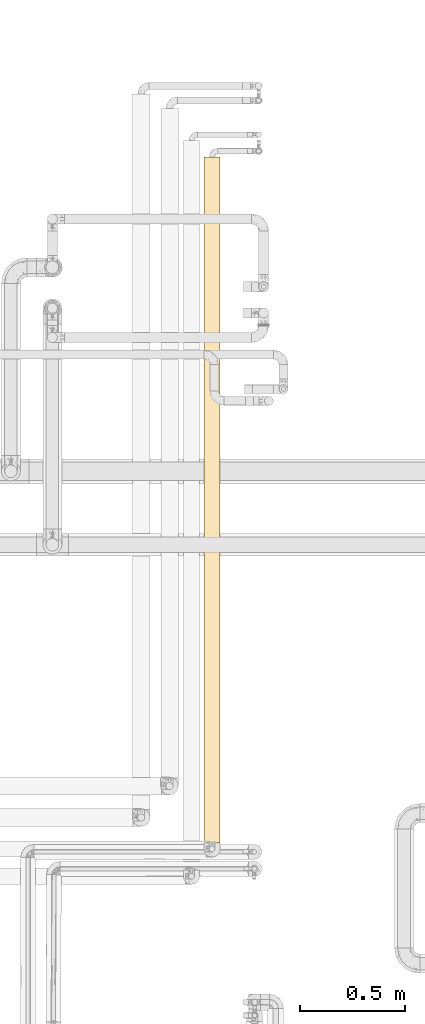
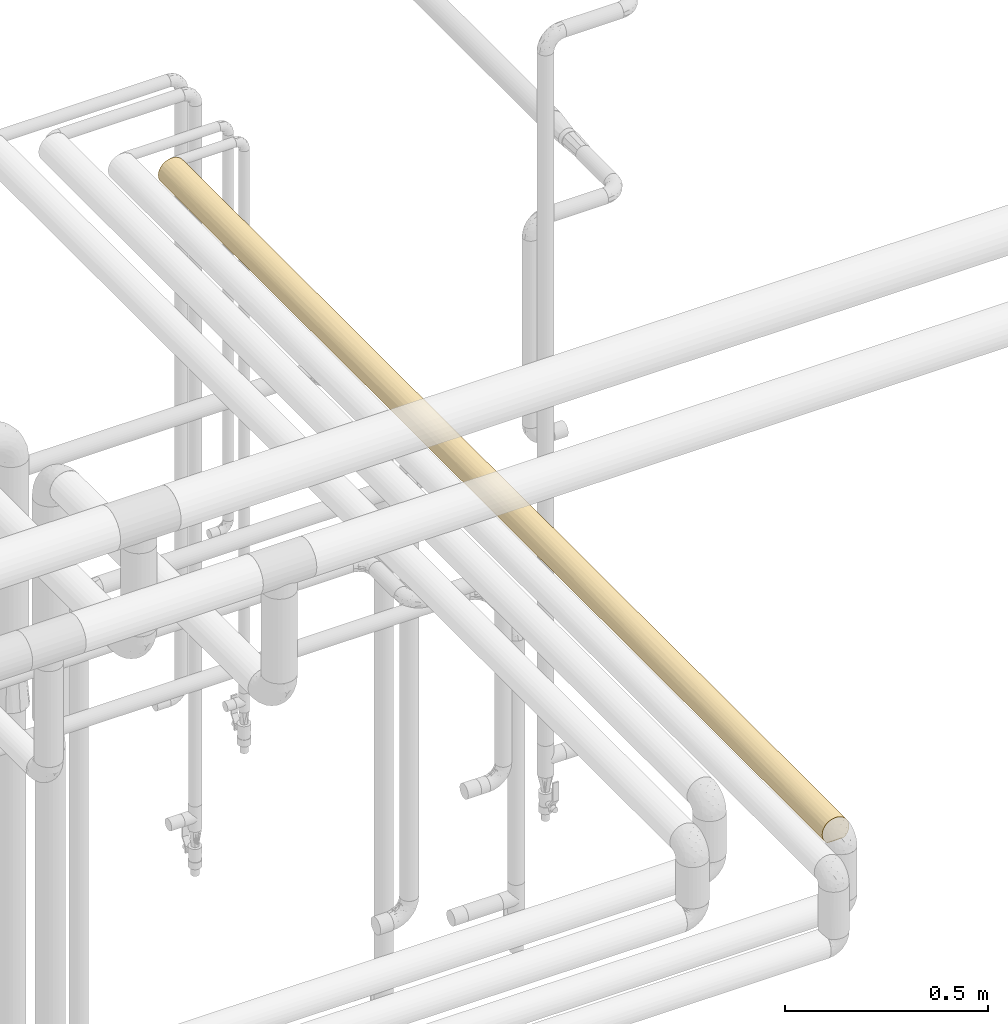
# One storey, part 34 of 827: 1 covering.
"""IFC2X3 building model written with IfcOpenShell, lengths in millimetres."""

from ifc_helpers import new_model, entity, si_unit, converted_unit, derived_unit, direction, frame, origin, place, context, subcontext, project, spatial, faceted_brep, element, save


model = new_model("IFC2X3")

# Units and contexts
model_context = context("Model", 3, precision=0.01, world=origin(), true_north=direction((6.12303176911189e-17, 1.0)))
body_context = subcontext(model_context, "Body", "Model", "MODEL_VIEW")
ifc_project = project(units=[si_unit("LENGTHUNIT", "METRE", prefix="MILLI"), si_unit("AREAUNIT", "SQUARE_METRE"), si_unit("VOLUMEUNIT", "CUBIC_METRE"), converted_unit("PLANEANGLEUNIT", "DEGREE", entity("IfcRatioMeasure", 0.0174532925199433), si_unit("PLANEANGLEUNIT", "RADIAN"), dimensions=[0, 0, 0, 0, 0, 0, 0]), si_unit("MASSUNIT", "GRAM", prefix="KILO"), derived_unit("MASSDENSITYUNIT", [(si_unit("MASSUNIT", "GRAM", prefix="KILO"), 1), (si_unit("LENGTHUNIT", "METRE"), -3)]), derived_unit("MOMENTOFINERTIAUNIT", [(si_unit("LENGTHUNIT", "METRE"), 4)]), si_unit("TIMEUNIT", "SECOND"), si_unit("FREQUENCYUNIT", "HERTZ"), si_unit("THERMODYNAMICTEMPERATUREUNIT", "DEGREE_CELSIUS"), derived_unit("THERMALTRANSMITTANCEUNIT", [(si_unit("MASSUNIT", "GRAM", prefix="KILO"), 1), (si_unit("THERMODYNAMICTEMPERATUREUNIT", "KELVIN"), -1), (si_unit("TIMEUNIT", "SECOND"), -3)]), derived_unit("VOLUMETRICFLOWRATEUNIT", [(si_unit("LENGTHUNIT", "METRE"), 3), (si_unit("TIMEUNIT", "SECOND"), -1)]), derived_unit("MASSFLOWRATEUNIT", [(si_unit("MASSUNIT", "GRAM", prefix="KILO"), 1), (si_unit("TIMEUNIT", "SECOND"), -1)]), derived_unit("ROTATIONALFREQUENCYUNIT", [(si_unit("TIMEUNIT", "SECOND"), -1)]), si_unit("ELECTRICCURRENTUNIT", "AMPERE"), si_unit("ELECTRICVOLTAGEUNIT", "VOLT"), si_unit("POWERUNIT", "WATT"), si_unit("FORCEUNIT", "NEWTON", prefix="KILO"), si_unit("ILLUMINANCEUNIT", "LUX"), si_unit("LUMINOUSFLUXUNIT", "LUMEN"), si_unit("LUMINOUSINTENSITYUNIT", "CANDELA"), derived_unit("USERDEFINED", [(si_unit("MASSUNIT", "GRAM", prefix="KILO"), -1), (si_unit("LENGTHUNIT", "METRE"), -2), (si_unit("TIMEUNIT", "SECOND"), 3), (si_unit("LUMINOUSFLUXUNIT", "LUMEN"), 1)]), derived_unit("LINEARVELOCITYUNIT", [(si_unit("LENGTHUNIT", "METRE"), 1), (si_unit("TIMEUNIT", "SECOND"), -1)]), si_unit("PRESSUREUNIT", "PASCAL"), derived_unit("USERDEFINED", [(si_unit("LENGTHUNIT", "METRE"), -2), (si_unit("MASSUNIT", "GRAM", prefix="KILO"), 1), (si_unit("TIMEUNIT", "SECOND"), -2)]), derived_unit("LINEARFORCEUNIT", [(si_unit("MASSUNIT", "GRAM", prefix="KILO"), 1), (si_unit("LENGTHUNIT", "METRE"), 1), (si_unit("TIMEUNIT", "SECOND"), -2), (si_unit("LENGTHUNIT", "METRE"), -1)]), derived_unit("PLANARFORCEUNIT", [(si_unit("MASSUNIT", "GRAM", prefix="KILO"), 1), (si_unit("LENGTHUNIT", "METRE"), 1), (si_unit("TIMEUNIT", "SECOND"), -2), (si_unit("LENGTHUNIT", "METRE"), -2)])], contexts=[model_context])

# Site, building, storey
site_placement = place(None, origin())
site = spatial("IfcSite", under=ifc_project, at=site_placement, CompositionType="ELEMENT")
building_placement = place(site_placement, origin())
building = spatial("IfcBuilding", under=site, at=building_placement, CompositionType="ELEMENT")
storey_placement = place(building_placement, frame((0.0, 0.0, 28200.0)))
storey = spatial("IfcBuildingStorey", under=building, at=storey_placement, Name="08", CompositionType="ELEMENT", Elevation=28200.0)

# Covering
covering_placement = place(storey_placement, frame((18643.06, 12977.5, 2560.0)))
element("IfcCovering", 1, at=covering_placement, inside=storey, Name=":ADSK_", ObjectType=":ADSK_", PredefinedType="INSULATION", context=body_context, shape_type="Brep", body=[
    faceted_brep([(5.09, 1.6, 23.98), (9.31, 1.6, 16.91), (14.94, 1.6, 10.9), (65.05, 1.6, 10.9), (70.68, 1.6, 16.91), (74.9, 1.6, 23.98), (77.51, 1.6, 31.79), (78.4, 1.6, 40.0), (77.09, 1.6, 49.93), (73.25, 1.6, 59.2), (67.15, 1.6, 67.15), (59.2, 1.6, 73.25), (49.93, 1.6, 77.09), (40.0, 1.6, 78.4), (30.06, 1.6, 77.09), (20.8, 1.6, 73.25), (12.84, 1.6, 67.15), (6.74, 1.6, 59.2), (2.9, 1.6, 49.93), (1.6, 1.6, 40.0), (2.48, 1.6, 31.79), (20.8, 3269.97, 6.74), (12.84, 3269.97, 12.84), (6.74, 3269.97, 20.8), (2.9, 3269.97, 30.06), (1.6, 3269.97, 40.0), (2.9, 3269.97, 49.93), (6.74, 3269.97, 59.2), (12.84, 3269.97, 67.15), (20.8, 3269.97, 73.25), (30.06, 3269.97, 77.09), (40.0, 3269.97, 78.4), (49.93, 3269.97, 77.09), (59.2, 3269.97, 73.25), (67.15, 3269.97, 67.15), (73.25, 3269.97, 59.2), (77.09, 3269.97, 49.93), (78.4, 3269.97, 40.0), (77.09, 3269.97, 30.06), (73.25, 3269.97, 20.8), (67.15, 3269.97, 12.84), (59.2, 3269.97, 6.74), (49.93, 3269.97, 2.9), (40.0, 3269.97, 1.6), (30.06, 3269.97, 2.9), (9.53, 3010.78, 16.62), (3.58, 287.23, 27.82), (7.01, 218.66, 20.33), (2.29, 2945.41, 32.71), (2.42, 2648.32, 32.07), (1.6, 2837.22, 40.0), (40.0, 3053.6, 1.6), (11.96, 287.24, 13.75), (27.74, 2411.32, 3.6), (17.45, 2441.81, 8.91), (25.3, 2740.25, 4.52), (15.56, 482.9, 10.37), (11.05, 642.7, 14.76), (25.3, 3024.92, 4.52), (6.82, 785.7, 20.65), (6.41, 1085.46, 21.37), (12.04, 950.32, 13.67), (20.48, 5.57, 6.92), (23.31, 384.99, 5.41), (26.63, 8.5, 4.0), (29.53, 688.07, 3.05), (29.96, 1009.3, 2.93), (40.0, 876.39, 1.6), (7.01, 485.18, 20.33), (3.13, 914.93, 29.25), (2.85, 616.82, 30.25), (1.6, 217.97, 40.0), (3.89, 3075.32, 26.92), (4.52, 2864.65, 25.3), (30.06, 1571.68, 2.9), (31.96, 1342.7, 2.45), (24.44, 1282.91, 4.89), (40.0, 660.01, 1.6), (40.0, 443.64, 1.6), (29.69, 2162.87, 3.0), (40.0, 2404.48, 1.6), (40.0, 2073.18, 1.6), (5.69, 2271.69, 22.74), (9.53, 2546.31, 16.62), (12.23, 2165.35, 13.47), (32.71, 2945.41, 2.29), (31.75, 335.45, 2.49), (33.21, 10.29, 2.2), (17.64, 278.27, 8.77), (16.62, 2945.7, 9.53), (3.15, 2416.6, 29.19), (5.14, 2608.73, 23.87), (40.0, 227.27, 1.6), (40.0, 10.9, 1.6), (33.12, 2708.32, 2.22), (1.6, 3053.6, 40.0), (1.6, 434.34, 40.0), (17.89, 2702.85, 8.6), (11.76, 2778.54, 13.97), (7.41, 2764.76, 19.68), (22.88, 606.06, 5.62), (23.89, 824.3, 5.13), (20.15, 1008.07, 7.12), (2.89, 1214.71, 30.1), (2.17, 1410.78, 33.38), (5.1, 1514.03, 23.97), (21.55, 2136.0, 6.32), (13.21, 1309.36, 12.48), (7.75, 1322.72, 19.14), (9.43, 1672.96, 16.75), (1.6, 867.09, 40.0), (1.6, 650.71, 40.0), (23.71, 1722.29, 5.22), (29.73, 1907.53, 2.99), (2.76, 1900.55, 30.62), (1.6, 1732.58, 40.0), (1.6, 1755.36, 40.0), (1.6, 1971.73, 40.0), (1.6, 2068.53, 40.0), (40.0, 2837.22, 1.6), (40.0, 2620.85, 1.6), (40.0, 1741.88, 1.6), (16.5, 1685.42, 9.62), (18.92, 1911.29, 7.9), (18.53, 1316.67, 8.16), (6.95, 1935.25, 20.43), (12.47, 1900.89, 13.22), (2.61, 2177.15, 31.22), (40.0, 1092.76, 1.6), (40.0, 1525.51, 1.6), (20.92, 1497.18, 6.67), (2.48, 1624.39, 31.78), (4.55, 1739.98, 25.23), (1.6, 1516.21, 40.0), (1.6, 1299.83, 40.0), (1.6, 2404.48, 40.0), (1.6, 2620.85, 40.0), (17.22, 717.19, 9.08), (1.6, 1083.46, 40.0), (1.6, 1538.99, 40.0), (1.6, 2188.11, 40.0), (40.0, 1309.13, 1.6), (1.6, 1203.04, 40.0), (75.47, 3024.92, 25.3), (56.56, 857.24, 5.35), (50.46, 688.07, 3.05), (50.03, 1009.3, 2.93), (63.37, 3010.78, 9.53), (72.98, 218.66, 20.33), (72.98, 485.18, 20.33), (76.41, 287.23, 27.82), (53.36, 8.5, 4.0), (46.78, 10.29, 2.2), (48.24, 335.45, 2.49), (55.9, 2520.7, 5.04), (60.1, 2733.21, 7.28), (63.37, 2546.31, 9.53), (78.4, 3053.6, 40.0), (57.31, 2271.77, 5.72), (66.54, 2165.74, 12.25), (70.04, 919.72, 16.08), (73.58, 1085.46, 21.37), (73.95, 783.02, 22.06), (56.68, 384.99, 5.41), (59.51, 5.57, 6.92), (65.02, 1839.13, 10.87), (55.52, 1623.09, 4.87), (59.59, 1936.52, 6.97), (68.03, 287.24, 13.75), (53.07, 3075.32, 3.89), (47.28, 2945.41, 2.29), (48.23, 1681.27, 2.49), (48.25, 1452.35, 2.49), (70.46, 2945.7, 16.62), (77.14, 616.82, 30.25), (78.4, 434.34, 40.0), (77.09, 953.6, 30.08), (71.08, 2441.81, 17.45), (75.47, 2740.25, 25.3), (76.39, 2411.32, 27.74), (65.4, 500.22, 11.2), (62.6, 316.33, 8.96), (77.7, 2945.41, 32.71), (54.69, 2864.65, 4.52), (49.4, 1907.53, 2.77), (69.32, 674.48, 15.2), (78.4, 217.97, 40.0), (77.77, 2708.32, 33.12), (47.92, 2648.32, 2.42), (62.77, 717.19, 9.08), (71.39, 2702.85, 17.89), (66.03, 2778.54, 11.76), (64.73, 1082.09, 10.62), (76.56, 1186.26, 28.26), (78.4, 1251.44, 40.0), (57.11, 606.06, 5.62), (55.55, 1282.91, 4.89), (64.89, 1453.94, 10.76), (78.4, 2404.48, 40.0), (78.4, 2020.13, 40.0), (77.3, 2137.55, 30.89), (73.35, 1902.54, 20.97), (76.71, 1827.96, 28.73), (78.4, 867.09, 40.0), (78.4, 650.71, 40.0), (74.21, 1674.15, 22.56), (78.4, 2837.23, 40.0), (78.4, 2620.85, 40.0), (73.68, 2136.0, 21.55), (76.56, 1425.24, 28.26), (76.74, 1626.22, 28.86), (78.4, 1635.78, 40.0), (69.16, 1973.33, 15.02), (71.97, 1463.8, 18.73), (69.64, 1124.78, 15.59), (47.0, 2443.34, 2.24), (48.04, 2238.83, 2.45), (47.35, 1224.47, 2.31), (69.81, 1753.65, 15.79), (56.7, 1071.61, 5.42), (63.37, 725.25, 70.46), (66.97, 1097.92, 67.33), (58.66, 997.02, 73.55), (70.46, 2945.7, 63.37), (70.46, 325.87, 63.37), (75.47, 3024.92, 54.69), (77.77, 2708.32, 46.88), (75.47, 2740.25, 54.69), (76.39, 2411.32, 52.25), (75.47, 246.65, 54.69), (75.47, 531.31, 54.69), (77.7, 326.15, 47.28), (77.7, 2945.41, 47.28), (53.07, 196.25, 76.1), (47.28, 326.15, 77.7), (54.69, 406.92, 75.47), (53.87, 721.15, 75.8), (71.37, 2511.14, 62.14), (73.68, 2136.0, 58.44), (63.37, 260.79, 70.46), (47.61, 1799.87, 77.63), (58.62, 1900.2, 73.58), (49.32, 2075.07, 77.25), (71.08, 829.75, 62.54), (76.39, 860.24, 52.25), (60.1, 2733.21, 72.71), (55.74, 2517.59, 75.02), (63.37, 2546.31, 70.46), (69.59, 1291.22, 64.47), (60.28, 1309.05, 72.6), (53.07, 3075.32, 76.1), (47.28, 2945.41, 77.7), (73.68, 1135.57, 58.44), (77.3, 1134.01, 49.1), (73.63, 1373.61, 58.52), (63.37, 3010.78, 70.46), (66.03, 2778.54, 68.23), (77.77, 563.24, 46.88), (47.1, 575.88, 77.73), (40.0, 434.34, 78.4), (40.0, 2837.22, 78.4), (40.0, 3053.6, 78.4), (40.0, 217.97, 78.4), (54.69, 2864.65, 75.47), (47.92, 2648.32, 77.57), (71.39, 568.72, 62.1), (66.03, 493.02, 68.23), (60.1, 538.36, 72.71), (70.94, 2728.5, 62.74), (77.3, 2137.55, 49.1), (76.71, 1443.61, 51.26), (66.93, 2236.36, 67.36), (76.68, 1825.68, 51.33), (56.6, 2260.66, 74.62), (40.0, 1538.99, 78.4), (50.86, 1200.22, 76.82), (52.17, 1555.42, 76.41), (40.0, 1251.44, 78.4), (40.0, 1203.04, 78.4), (68.5, 1875.9, 65.72), (74.35, 1633.67, 57.15), (61.47, 1611.08, 71.83), (73.41, 1869.19, 58.91), (40.0, 867.09, 78.4), (47.04, 793.01, 77.74), (45.92, 1021.5, 77.93), (48.83, 2365.17, 77.36), (52.33, 932.05, 76.36), (40.0, 650.71, 78.4), (69.92, 1514.01, 64.05), (40.0, 2620.85, 78.4), (40.0, 2404.48, 78.4), (40.0, 2188.1, 78.4), (40.0, 1971.73, 78.4), (40.0, 1755.36, 78.4), (40.0, 1635.78, 78.4), (40.0, 2020.13, 78.4), (9.53, 725.25, 63.37), (12.66, 1097.92, 66.97), (6.44, 997.02, 58.66), (16.62, 2945.7, 70.46), (16.62, 325.87, 70.46), (25.3, 3024.92, 75.47), (33.12, 2708.32, 77.77), (25.3, 2740.25, 75.47), (27.74, 2411.32, 76.39), (25.3, 246.65, 75.47), (25.3, 531.31, 75.47), (32.71, 326.15, 77.7), (32.71, 2945.41, 77.7), (3.89, 196.25, 53.07), (2.29, 326.15, 47.28), (4.52, 406.92, 54.69), (4.19, 721.15, 53.87), (17.85, 2511.14, 71.37), (21.55, 2136.0, 73.68), (9.53, 260.79, 63.37), (2.36, 1799.87, 47.61), (6.41, 1900.2, 58.62), (2.74, 2075.07, 49.32), (17.45, 829.75, 71.08), (27.74, 860.24, 76.39), (7.28, 2733.21, 60.1), (4.97, 2517.59, 55.74), (9.53, 2546.31, 63.37), (15.52, 1291.22, 69.59), (7.39, 1309.05, 60.28), (3.89, 3075.32, 53.07), (2.29, 2945.41, 47.28), (21.55, 1135.57, 73.68), (30.89, 1134.01, 77.3), (21.47, 1373.61, 73.63), (9.53, 3010.78, 63.37), (11.76, 2778.54, 66.03), (33.12, 563.24, 77.77), (2.26, 575.88, 47.1), (4.52, 2864.65, 54.69), (2.42, 2648.32, 47.92), (17.89, 568.72, 71.39), (11.76, 493.02, 66.03), (7.28, 538.36, 60.1), (17.25, 2728.5, 70.94), (30.89, 2137.55, 77.3), (28.73, 1443.61, 76.71), (12.63, 2236.36, 66.93), (28.66, 1825.68, 76.68), (5.37, 2260.66, 56.6), (3.17, 1200.22, 50.86), (3.58, 1555.42, 52.17), (14.27, 1875.9, 68.5), (22.84, 1633.67, 74.35), (8.16, 1611.08, 61.47), (21.08, 1869.19, 73.41), (2.25, 793.01, 47.04), (2.06, 1021.5, 45.92), (2.63, 2365.17, 48.83), (3.63, 932.05, 52.33), (15.94, 1514.01, 69.92)], [[[0, 1, 2, 3, 4, 5, 6, 7, 8, 9, 10, 11, 12, 13, 14, 15, 16, 17, 18, 19, 20]], [[21, 22, 23, 24, 25, 26, 27, 28, 29, 30, 31, 32, 33, 34, 35, 36, 37, 38, 39, 40, 41, 42, 43, 44]], [[22, 45, 23]], [[46, 47, 0]], [[48, 49, 50]], [[44, 43, 51]], [[52, 1, 47]], [[53, 54, 55]], [[56, 52, 57]], [[44, 58, 21]], [[59, 60, 61]], [[62, 63, 64]], [[65, 66, 67]], [[52, 68, 57]], [[69, 59, 70]], [[20, 19, 71]], [[48, 72, 73]], [[74, 75, 76]], [[77, 78, 65, 67]], [[2, 1, 52]], [[79, 80, 81]], [[82, 83, 84]], [[58, 85, 55]], [[47, 68, 52]], [[86, 65, 78]], [[87, 64, 86]], [[2, 52, 88]], [[21, 58, 89]], [[68, 46, 70]], [[90, 91, 82]], [[92, 93, 87]], [[46, 0, 20]], [[94, 53, 55]], [[21, 89, 22]], [[45, 22, 89]], [[24, 72, 48]], [[24, 48, 95]], [[86, 64, 63]], [[78, 92, 86]], [[52, 56, 88]], [[46, 71, 96]], [[70, 46, 96]], [[89, 97, 98]], [[55, 85, 94]], [[99, 45, 98]], [[54, 84, 83]], [[87, 86, 92]], [[86, 63, 65]], [[63, 100, 65]], [[66, 65, 101]], [[102, 76, 66]], [[103, 104, 105]], [[53, 79, 106]], [[107, 108, 109]], [[110, 70, 96, 111]], [[59, 69, 60]], [[98, 45, 89]], [[20, 71, 46]], [[72, 45, 73]], [[112, 113, 74]], [[114, 115, 116, 117, 118]], [[51, 85, 44]], [[89, 58, 55]], [[85, 51, 119]], [[85, 119, 94]], [[44, 85, 58]], [[94, 119, 120, 80]], [[53, 106, 54]], [[94, 80, 53]], [[113, 106, 79]], [[74, 113, 121]], [[113, 81, 121]], [[122, 123, 112]], [[124, 102, 107]], [[109, 125, 126]], [[84, 54, 106]], [[98, 97, 83]], [[126, 123, 122]], [[84, 125, 82]], [[127, 125, 114]], [[127, 90, 82]], [[75, 128, 66]], [[125, 127, 82]], [[74, 121, 129]], [[112, 130, 122]], [[114, 118, 127]], [[131, 132, 105]], [[105, 132, 109]], [[69, 103, 60]], [[95, 48, 50]], [[133, 104, 134]], [[95, 25, 24]], [[49, 48, 73]], [[83, 82, 91]], [[49, 135, 136, 50]], [[24, 23, 72]], [[45, 72, 23]], [[65, 100, 101]], [[66, 76, 75]], [[137, 61, 102]], [[102, 61, 107]], [[108, 107, 60]], [[130, 107, 122]], [[59, 57, 68]], [[107, 61, 60]], [[57, 61, 137]], [[70, 59, 68]], [[110, 69, 70]], [[69, 138, 103]], [[131, 133, 139, 115]], [[108, 103, 105]], [[133, 131, 104]], [[115, 114, 131]], [[132, 131, 114]], [[114, 125, 132]], [[84, 126, 125]], [[125, 109, 132]], [[107, 109, 122]], [[123, 84, 106]], [[122, 109, 126]], [[84, 123, 126]], [[113, 123, 106]], [[113, 112, 123]], [[130, 74, 76]], [[74, 130, 112]], [[124, 130, 76]], [[127, 118, 140, 135]], [[90, 135, 49]], [[135, 90, 127]], [[90, 49, 91]], [[49, 73, 91]], [[99, 91, 73]], [[89, 55, 97]], [[83, 91, 99]], [[55, 54, 97]], [[83, 97, 54]], [[61, 57, 59]], [[57, 137, 56]], [[100, 56, 137]], [[88, 56, 63]], [[63, 62, 88]], [[2, 88, 62]], [[105, 104, 131]], [[134, 104, 103]], [[102, 124, 76]], [[107, 130, 124]], [[0, 47, 1]], [[68, 47, 46]], [[45, 99, 73]], [[83, 99, 98]], [[56, 100, 63]], [[101, 137, 102]], [[137, 101, 100]], [[66, 101, 102]], [[80, 79, 53]], [[81, 113, 79]], [[129, 75, 74]], [[75, 129, 141, 128]], [[103, 108, 60]], [[128, 67, 66]], [[109, 108, 105]], [[138, 69, 110]], [[103, 138, 142, 134]], [[38, 143, 39]], [[144, 145, 146]], [[41, 40, 147]], [[148, 149, 150]], [[151, 152, 153]], [[154, 155, 156]], [[38, 37, 157]], [[158, 156, 159]], [[160, 161, 162]], [[151, 163, 164]], [[165, 166, 167]], [[168, 148, 4]], [[42, 169, 170]], [[171, 166, 172]], [[39, 143, 173]], [[150, 174, 175]], [[174, 162, 176]], [[177, 178, 179]], [[3, 168, 4]], [[180, 181, 163]], [[143, 182, 178]], [[170, 169, 183]], [[153, 145, 163]], [[148, 5, 4]], [[78, 153, 92]], [[184, 121, 81]], [[149, 180, 185]], [[92, 153, 152]], [[5, 150, 6]], [[150, 186, 6]], [[187, 179, 178]], [[39, 173, 40]], [[173, 147, 40]], [[170, 188, 119]], [[42, 51, 43]], [[181, 3, 164]], [[185, 180, 189]], [[174, 150, 149]], [[6, 186, 7]], [[173, 190, 191]], [[178, 182, 187]], [[155, 147, 191]], [[152, 93, 92]], [[189, 144, 192]], [[176, 193, 194]], [[145, 78, 77, 67]], [[153, 163, 151]], [[146, 145, 67]], [[195, 163, 145]], [[177, 159, 156]], [[196, 197, 192]], [[198, 199, 200]], [[201, 200, 202]], [[162, 174, 149]], [[174, 203, 204, 175]], [[191, 147, 173]], [[175, 186, 150]], [[169, 147, 183]], [[205, 201, 202]], [[166, 196, 172]], [[157, 182, 38]], [[173, 143, 178]], [[182, 157, 206]], [[182, 206, 187]], [[38, 182, 143]], [[187, 206, 207, 198]], [[179, 208, 177]], [[187, 198, 179]], [[179, 200, 208]], [[209, 205, 210]], [[202, 199, 211]], [[159, 212, 165]], [[205, 209, 213]], [[166, 197, 196]], [[203, 176, 194]], [[214, 161, 160]], [[159, 177, 208]], [[191, 190, 156]], [[208, 201, 212]], [[159, 167, 158]], [[184, 158, 167]], [[158, 215, 154]], [[184, 81, 216]], [[80, 216, 81]], [[166, 184, 167]], [[159, 165, 167]], [[141, 172, 217]], [[213, 197, 218]], [[195, 144, 189]], [[214, 197, 213]], [[160, 162, 185]], [[209, 211, 194]], [[171, 184, 166]], [[42, 170, 51]], [[119, 51, 170]], [[188, 170, 183]], [[155, 154, 183]], [[215, 120, 188]], [[42, 41, 169]], [[147, 169, 41]], [[146, 128, 217]], [[146, 219, 144]], [[185, 162, 149]], [[176, 162, 161]], [[176, 161, 193]], [[213, 193, 161]], [[215, 216, 80]], [[184, 216, 158]], [[180, 149, 168]], [[160, 189, 192]], [[189, 160, 185]], [[214, 160, 192]], [[181, 180, 168]], [[195, 180, 163]], [[3, 181, 168]], [[164, 163, 181]], [[198, 200, 179]], [[202, 200, 199]], [[173, 178, 190]], [[155, 191, 156]], [[178, 177, 190]], [[156, 190, 177]], [[156, 158, 154]], [[147, 155, 183]], [[215, 158, 216]], [[183, 154, 188]], [[205, 213, 218]], [[213, 209, 193]], [[197, 214, 192]], [[213, 161, 214]], [[196, 219, 217]], [[129, 121, 171]], [[196, 217, 172]], [[171, 172, 129]], [[128, 146, 67]], [[128, 141, 217]], [[121, 184, 171]], [[149, 148, 168]], [[5, 148, 150]], [[201, 205, 218]], [[205, 202, 210]], [[212, 201, 218]], [[201, 208, 200]], [[212, 218, 165]], [[208, 212, 159]], [[218, 197, 165]], [[166, 165, 197]], [[202, 211, 210]], [[211, 209, 210]], [[78, 145, 153]], [[180, 195, 189]], [[145, 144, 195]], [[217, 219, 146]], [[196, 192, 219]], [[192, 144, 219]], [[203, 174, 176]], [[120, 119, 188]], [[194, 193, 209]], [[120, 215, 80]], [[154, 215, 188]], [[172, 141, 129]], [[220, 221, 222]], [[223, 35, 34]], [[9, 224, 10]], [[225, 36, 35]], [[226, 227, 228]], [[227, 225, 223]], [[224, 229, 230]], [[229, 231, 230]], [[227, 232, 225]], [[226, 206, 232]], [[12, 233, 234]], [[234, 233, 235]], [[220, 222, 236]], [[237, 238, 228]], [[11, 10, 239]], [[240, 241, 242]], [[243, 230, 244]], [[9, 8, 229]], [[245, 246, 247]], [[221, 248, 249]], [[250, 32, 251]], [[252, 253, 254]], [[255, 256, 223]], [[223, 34, 255]], [[9, 229, 224]], [[232, 206, 157]], [[231, 186, 175]], [[257, 244, 230]], [[8, 7, 186]], [[36, 157, 37]], [[224, 239, 10]], [[258, 259, 234]], [[260, 251, 261]], [[259, 262, 234]], [[12, 262, 13]], [[32, 31, 261]], [[32, 261, 251]], [[263, 251, 264]], [[224, 265, 266]], [[230, 231, 257]], [[267, 239, 266]], [[34, 33, 255]], [[247, 268, 256]], [[203, 194, 253]], [[198, 269, 199]], [[253, 270, 254]], [[237, 271, 238]], [[199, 269, 272]], [[241, 271, 273]], [[243, 221, 220]], [[266, 239, 224]], [[233, 239, 235]], [[250, 255, 33]], [[256, 245, 247]], [[186, 231, 8]], [[223, 225, 35]], [[232, 36, 225]], [[274, 275, 276]], [[275, 274, 277, 278]], [[231, 175, 257]], [[8, 231, 229]], [[257, 175, 204, 203]], [[226, 198, 207, 206]], [[244, 252, 243]], [[257, 203, 244]], [[244, 253, 252]], [[211, 272, 270]], [[270, 194, 211]], [[271, 279, 238]], [[270, 280, 254]], [[276, 281, 241]], [[228, 269, 198]], [[282, 279, 280]], [[272, 211, 199]], [[221, 243, 252]], [[266, 265, 220]], [[252, 254, 248]], [[221, 249, 222]], [[249, 275, 222]], [[236, 235, 267]], [[275, 249, 276]], [[283, 284, 285]], [[285, 278, 283]], [[281, 276, 249]], [[286, 242, 273]], [[275, 285, 287]], [[276, 240, 274]], [[284, 288, 258]], [[227, 226, 232]], [[36, 232, 157]], [[227, 237, 228]], [[269, 228, 238]], [[198, 226, 228]], [[256, 268, 223]], [[237, 247, 271]], [[273, 271, 247]], [[279, 271, 241]], [[246, 273, 247]], [[281, 279, 241]], [[279, 289, 280]], [[12, 234, 262]], [[258, 235, 236]], [[235, 258, 234]], [[284, 258, 236]], [[12, 11, 233]], [[239, 233, 11]], [[264, 251, 260]], [[251, 263, 250]], [[264, 260, 290, 291]], [[246, 286, 273]], [[255, 250, 263]], [[33, 32, 250]], [[236, 222, 287]], [[203, 253, 244]], [[287, 285, 284]], [[278, 285, 275]], [[236, 287, 284]], [[275, 287, 222]], [[288, 284, 283]], [[288, 259, 258]], [[270, 253, 194]], [[272, 269, 238]], [[224, 230, 265]], [[267, 266, 220]], [[230, 243, 265]], [[220, 265, 243]], [[236, 267, 220]], [[239, 267, 235]], [[245, 255, 263]], [[268, 247, 237]], [[255, 245, 256]], [[246, 263, 264]], [[263, 246, 245]], [[286, 264, 291]], [[264, 286, 246]], [[286, 292, 242]], [[240, 242, 293]], [[241, 273, 242]], [[240, 293, 294, 295, 274]], [[241, 240, 276]], [[237, 227, 268]], [[227, 223, 268]], [[249, 289, 281]], [[279, 281, 289]], [[280, 270, 272]], [[248, 254, 289]], [[280, 272, 282]], [[289, 254, 280]], [[249, 248, 289]], [[252, 248, 221]], [[272, 238, 282]], [[238, 279, 282]], [[292, 286, 291]], [[242, 292, 296, 293]], [[297, 298, 299]], [[300, 29, 28]], [[15, 301, 16]], [[302, 30, 29]], [[303, 304, 305]], [[304, 302, 300]], [[301, 306, 307]], [[306, 308, 307]], [[304, 309, 302]], [[303, 260, 309]], [[18, 310, 311]], [[311, 310, 312]], [[297, 299, 313]], [[314, 315, 305]], [[17, 16, 316]], [[317, 318, 319]], [[320, 307, 321]], [[15, 14, 306]], [[322, 323, 324]], [[298, 325, 326]], [[327, 26, 328]], [[329, 330, 331]], [[332, 333, 300]], [[300, 28, 332]], [[15, 306, 301]], [[309, 260, 261]], [[308, 262, 259]], [[334, 321, 307]], [[14, 13, 262]], [[30, 261, 31]], [[301, 316, 16]], [[335, 96, 311]], [[50, 328, 95]], [[96, 71, 311]], [[18, 71, 19]], [[26, 25, 95]], [[26, 95, 328]], [[336, 328, 337]], [[301, 338, 339]], [[307, 308, 334]], [[340, 316, 339]], [[28, 27, 332]], [[324, 341, 333]], [[330, 283, 278, 277]], [[342, 296, 292, 291]], [[330, 343, 331]], [[314, 344, 315]], [[296, 342, 345]], [[318, 344, 346]], [[320, 298, 297]], [[339, 316, 301]], [[310, 316, 312]], [[327, 332, 27]], [[333, 322, 324]], [[262, 308, 14]], [[300, 302, 29]], [[309, 30, 302]], [[139, 347, 348]], [[347, 139, 133, 134, 142]], [[308, 259, 334]], [[14, 308, 306]], [[334, 259, 288, 283]], [[303, 291, 290, 260]], [[321, 329, 320]], [[334, 283, 321]], [[321, 330, 329]], [[295, 345, 343]], [[343, 277, 274, 295]], [[344, 349, 315]], [[343, 350, 331]], [[348, 351, 318]], [[305, 342, 291]], [[352, 349, 350]], [[345, 295, 294, 293, 296]], [[298, 320, 329]], [[339, 338, 297]], [[329, 331, 325]], [[298, 326, 299]], [[326, 347, 299]], [[313, 312, 340]], [[347, 326, 348]], [[110, 353, 354]], [[354, 142, 138, 110]], [[351, 348, 326]], [[355, 319, 346]], [[347, 354, 356]], [[348, 317, 139]], [[353, 111, 335]], [[304, 303, 309]], [[30, 309, 261]], [[304, 314, 305]], [[342, 305, 315]], [[291, 303, 305]], [[333, 341, 300]], [[314, 324, 344]], [[346, 344, 324]], [[349, 344, 318]], [[323, 346, 324]], [[351, 349, 318]], [[349, 357, 350]], [[18, 311, 71]], [[335, 312, 313]], [[312, 335, 311]], [[353, 335, 313]], [[18, 17, 310]], [[316, 310, 17]], [[337, 328, 50]], [[328, 336, 327]], [[337, 50, 136, 135]], [[323, 355, 346]], [[332, 327, 336]], [[27, 26, 327]], [[313, 299, 356]], [[283, 330, 321]], [[356, 354, 353]], [[142, 354, 347]], [[313, 356, 353]], [[347, 356, 299]], [[111, 353, 110]], [[111, 96, 335]], [[343, 330, 277]], [[345, 342, 315]], [[301, 307, 338]], [[340, 339, 297]], [[307, 320, 338]], [[297, 338, 320]], [[313, 340, 297]], [[316, 340, 312]], [[322, 332, 336]], [[341, 324, 314]], [[332, 322, 333]], [[323, 336, 337]], [[336, 323, 322]], [[355, 337, 135]], [[337, 355, 323]], [[355, 140, 319]], [[317, 319, 117]], [[318, 346, 319]], [[317, 117, 116, 115, 139]], [[318, 317, 348]], [[314, 304, 341]], [[304, 300, 341]], [[326, 357, 351]], [[349, 351, 357]], [[350, 343, 345]], [[325, 331, 357]], [[350, 345, 352]], [[357, 331, 350]], [[326, 325, 357]], [[329, 325, 298]], [[345, 315, 352]], [[315, 349, 352]], [[140, 355, 135]], [[319, 140, 118, 117]], [[62, 64, 87, 93, 152, 151, 164, 3, 2]]]),
])

save(model, "model.ifc")
